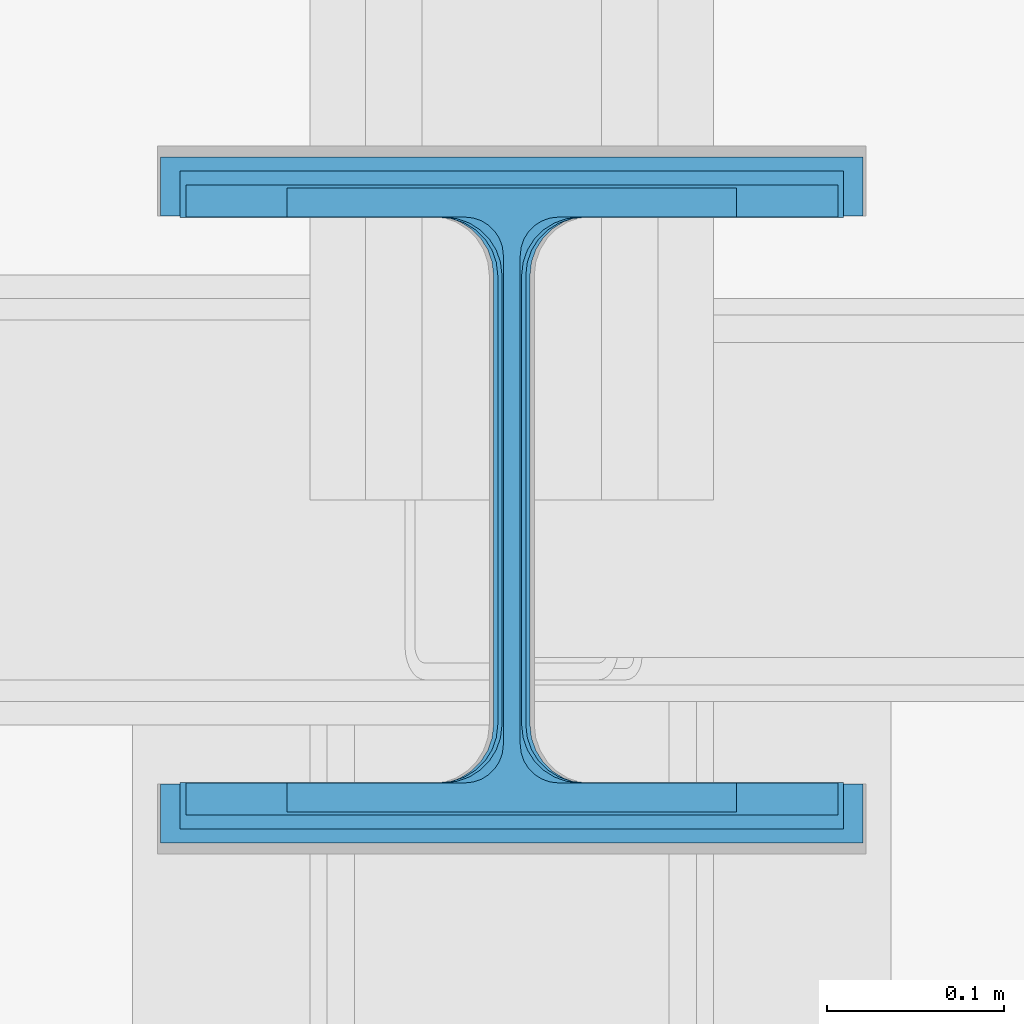
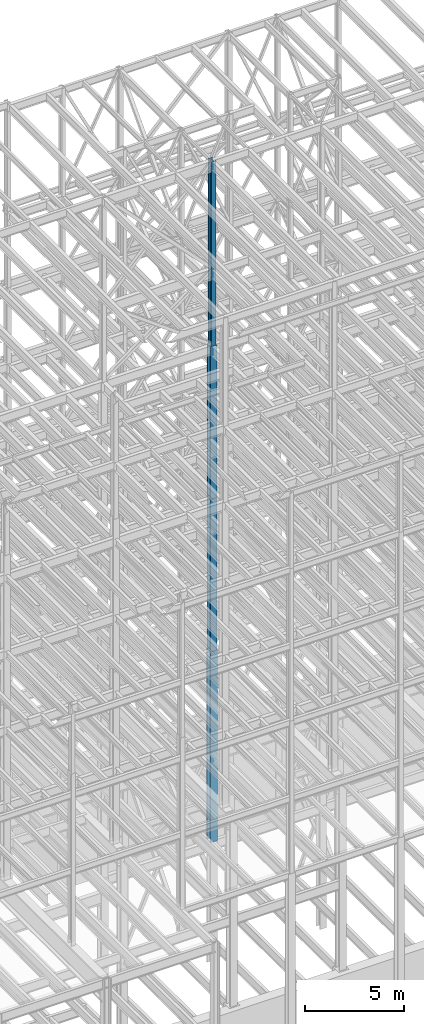
# One storey, part 38 of 150: 4 columns.
"""IFC2X3 building model written with IfcOpenShell, lengths in millimetres."""

from ifc_helpers import new_model, si_unit, frame, origin_with_axes, origin_2d_with_axis, place, context, subcontext, project, spatial, i_section, extrude, material, type_object, element, save


model = new_model("IFC2X3")

# Units and contexts
model_context = context("Model", 3, precision=1e-05, world=origin_with_axes())
body_context = subcontext(model_context, "Body", "Model", "MODEL_VIEW")
ifc_project = project(units=[si_unit("LENGTHUNIT", "METRE", prefix="MILLI"), si_unit("AREAUNIT", "SQUARE_METRE"), si_unit("VOLUMEUNIT", "CUBIC_METRE"), si_unit("MASSUNIT", "GRAM", prefix="KILO"), si_unit("TIMEUNIT", "SECOND"), si_unit("PLANEANGLEUNIT", "RADIAN"), si_unit("SOLIDANGLEUNIT", "STERADIAN"), si_unit("THERMODYNAMICTEMPERATUREUNIT", "DEGREE_CELSIUS"), si_unit("LUMINOUSINTENSITYUNIT", "LUMEN")], contexts=[model_context])

# Site, building, storey
site_placement = place(None, origin_with_axes())
site = spatial("IfcSite", under=ifc_project, at=site_placement, CompositionType="ELEMENT")
building_placement = place(site_placement, origin_with_axes())
building = spatial("IfcBuilding", under=site, at=building_placement, Name="Undefined", CompositionType="ELEMENT")
storey_placement = place(building_placement, origin_with_axes())
storey = spatial("IfcBuildingStorey", under=building, at=storey_placement, Name="Undefined", CompositionType="ELEMENT", Elevation=0.0)

# Columns
ifc_material = material(Name="STEEL/A992")
column_type_1 = type_object("IfcColumnType", Name="W14X61", PredefinedType="NOTDEFINED")
column_1_placement = place(storey_placement, frame((56591.2, 22479.0, 54483.0), z_axis=(0.0, 0.0, 1.0), x_axis=(1.0, 0.0, 0.0)))
element("IfcColumn", 1, at=column_1_placement, inside=storey, type_object=column_type_1, material=ifc_material, Name="COLUMN", ObjectType="W14X61", context=body_context, shape_type="SweptSolid", body=[
    extrude(i_section(OverallWidth=254.0, OverallDepth=352.425, WebThickness=9.5249, FlangeThickness=16.383, FilletRadius=21.717, at=origin_2d_with_axis()), frame((0.0, 0.0, 11430.0), z_axis=(0.0, 0.0, -1.0), x_axis=(-1.0, 0.0, 0.0)), (0.0, 0.0, 1.0), 11430.0),
])
column_type_2 = type_object("IfcColumnType", Name="W14X132", PredefinedType="NOTDEFINED")
column_2_placement = place(storey_placement, frame((56591.2, 22479.0, 35585.4), z_axis=(0.0, 0.0, 1.0), x_axis=(1.0, 0.0, 0.0)))
element("IfcColumn", 2, at=column_2_placement, inside=storey, type_object=column_type_2, material=ifc_material, Name="COLUMN", ObjectType="W14X132", context=body_context, shape_type="SweptSolid", body=[
    extrude(i_section(OverallWidth=374.65, OverallDepth=371.475, WebThickness=15.875, FlangeThickness=26.162, FilletRadius=32.5755, at=origin_2d_with_axis()), frame((0.0, 0.0, 9448.8), z_axis=(0.0, 0.0, -1.0), x_axis=(-1.0, 0.0, 0.0)), (0.0, 0.0, 1.0), 9448.79999999999),
])
column_type_3 = type_object("IfcColumnType", Name="W14X90", PredefinedType="NOTDEFINED")
column_3_placement = place(storey_placement, frame((56591.2, 22479.0, 45034.2), z_axis=(0.0, 0.0, 1.0), x_axis=(1.0, 0.0, 0.0)))
element("IfcColumn", 3, at=column_3_placement, inside=storey, type_object=column_type_3, material=ifc_material, Name="COLUMN", ObjectType="W14X90", context=body_context, shape_type="SweptSolid", body=[
    extrude(i_section(OverallWidth=368.3, OverallDepth=355.6, WebThickness=11.1125, FlangeThickness=18.034, FilletRadius=32.7659, at=origin_2d_with_axis()), frame((0.0, 0.0, 9448.8), z_axis=(0.0, 0.0, -1.0), x_axis=(-1.0, 0.0, 0.0)), (0.0, 0.0, 1.0), 9448.8),
])
column_type_4 = type_object("IfcColumnType", Name="W14X176", PredefinedType="NOTDEFINED")
column_4_placement = place(storey_placement, frame((56591.2, 22479.0, 23774.4), z_axis=(0.0, 0.0, 1.0), x_axis=(1.0, 0.0, 0.0)))
element("IfcColumn", 4, at=column_4_placement, inside=storey, type_object=column_type_4, material=ifc_material, Name="COLUMN", ObjectType="W14X176", context=body_context, shape_type="SweptSolid", body=[
    extrude(i_section(OverallWidth=396.875, OverallDepth=387.35, WebThickness=20.6375, FlangeThickness=33.274, FilletRadius=33.401, at=origin_2d_with_axis()), frame((0.0, 0.0, 11811.0), z_axis=(0.0, 0.0, -1.0), x_axis=(-1.0, 0.0, 0.0)), (0.0, 0.0, 1.0), 11811.0),
])

save(model, "model.ifc")
